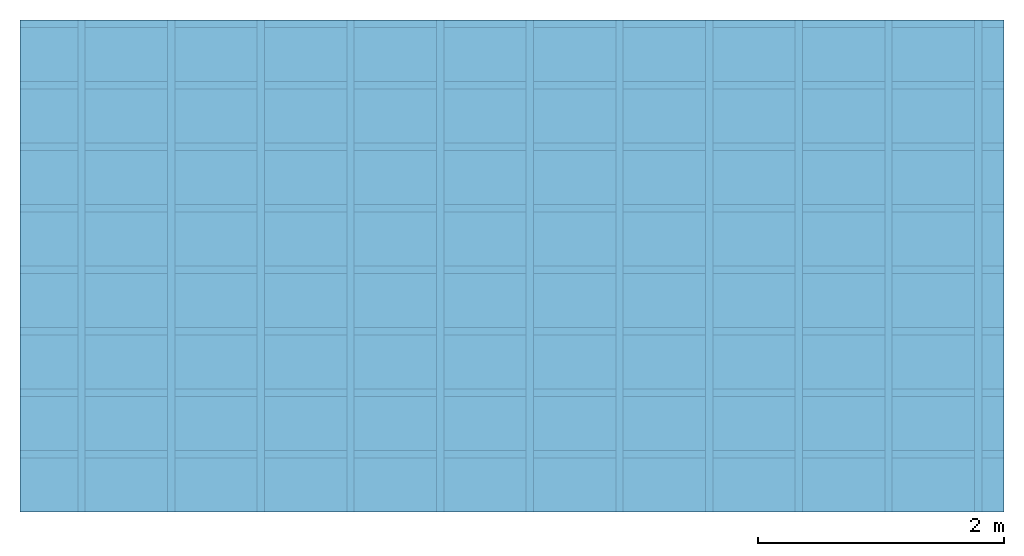
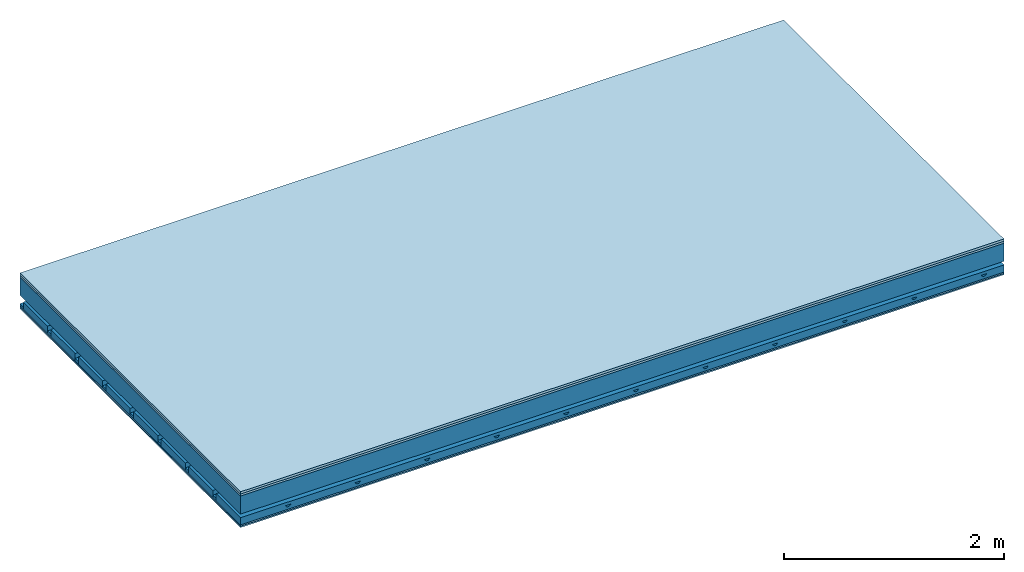
# One storey: 4 members, 4 plates, 1 element without a shape of its own.
"""IFC4 building model written with IfcOpenShell, lengths in metres."""

from ifc_helpers import new_model, si_unit, derived_unit, direction, frame, frame_2d, origin, origin_with_axes, place, context, project, spatial, polyline, rectangle, outline, extrude, material, layer, layer_set, type_object, element, aggregate, save


model = new_model("IFC4")

# Units and contexts
plan_context = context("Plan", 3, precision=1e-05, world=origin(), true_north=direction((0.0, 1.0)))
model_context = context("Model", 3, precision=1e-05, world=origin(), true_north=direction((0.0, 1.0)))
ifc_project = project(units=[si_unit("LENGTHUNIT", "METRE"), derived_unit("SOUNDPRESSUREUNIT", [(si_unit("PRESSUREUNIT", "PASCAL", prefix="MICRO"), 0)]), si_unit("ENERGYUNIT", "JOULE", prefix="MEGA"), si_unit("MASSUNIT", "GRAM", prefix="KILO"), derived_unit("THERMALTRANSMITTANCEUNIT", [(si_unit("POWERUNIT", "WATT"), 1), (si_unit("AREAUNIT", "SQUARE_METRE"), -1), (si_unit("THERMODYNAMICTEMPERATUREUNIT", "KELVIN"), -1)]), derived_unit("AREADENSITYUNIT", [(si_unit("MASSUNIT", "GRAM", prefix="KILO"), 1), (si_unit("AREAUNIT", "SQUARE_METRE"), -1)]), derived_unit("USERDEFINED", [(si_unit("ENERGYUNIT", "JOULE", prefix="MEGA"), 1), (si_unit("AREAUNIT", "SQUARE_METRE"), -1)])], contexts=[plan_context, model_context])

# Site, building, storey
site = spatial("IfcSite", under=ifc_project)
building_placement = place(None, origin())
building = spatial("IfcBuilding", under=site, at=building_placement)
storey_placement = place(building_placement, origin())
storey = spatial("IfcBuildingStorey", under=building, at=storey_placement)

# Slab, members, plates
ifc_material_1 = material(Name="Floor heating system Therm38 longitudinal", Category="03.007")
ifc_layer_1 = layer(ifc_material_1, 0.025, Name="On-material")
ifc_material_2 = material(Category="10.009")
ifc_layer_2 = layer(ifc_material_2, 0.022, Name="Impact sound insulation")
ifc_layer_3 = layer(None, 0.2, Name="Supporting structure")
ifc_material_3 = material(Name="no composite action")
ifc_layer_4 = layer(ifc_material_3, 0.0, Name="Bond")
ifc_layer_5 = layer(None, 0.093, Name="Coupling")
ifc_layer_6 = layer(None, 0.027, Name="Battens / profiles")
ifc_material_4 = material(Category="03.007")
ifc_layer_7 = layer(ifc_material_4, 0.015, Name="Ceiling covering 1st layer")
ifc_layer_8 = layer(ifc_material_4, 0.015, Name="Ceiling covering layer 2")
ifc_material_5 = material(Name="Glued joints")
ifc_layer_9 = layer(ifc_material_5, 0.0, Name="Surface / treatment")
ifc_layer_set = layer_set([ifc_layer_1, ifc_layer_2, ifc_layer_3, ifc_layer_4, ifc_layer_5, ifc_layer_6, ifc_layer_7, ifc_layer_8, ifc_layer_9])
slab_type = type_object("IfcSlabType", Name="A0901", PredefinedType="NOTDEFINED", material=ifc_layer_set)
slab_placement = place(None, frame((0.0, 0.0, 0.0), z_axis=(0.0, 0.0, -1.0), x_axis=(1.0, 0.0, 0.0)))
slab = element("IfcSlab", 1, at=slab_placement, inside=storey, type_object=slab_type, material=ifc_layer_set, Name="Slab #1")
ifc_material_6 = material()
member_1_placement = place(slab_placement, origin())
member_1 = element("IfcMember", 2, at=member_1_placement, material=ifc_material_6, Name="Supporting structure", context=plan_context, shape_type="SweptSolid", body=[
    extrude(rectangle(XDim=1.0, YDim=0.2, at=frame_2d((0.5, 0.1), x_axis=(1.0, 0.0))), frame((0.0, 4.0, 0.047), z_axis=(0.0, -1.0, 0.0), x_axis=(1.0, 0.0, 0.0)), (0.0, 0.0, 1.0), 4.0),
    extrude(rectangle(XDim=1.0, YDim=0.2, at=frame_2d((0.5, 0.1), x_axis=(1.0, 0.0))), frame((1.0, 4.0, 0.047), z_axis=(0.0, -1.0, 0.0), x_axis=(1.0, 0.0, 0.0)), (0.0, 0.0, 1.0), 4.0),
    extrude(rectangle(XDim=1.0, YDim=0.2, at=frame_2d((0.5, 0.1), x_axis=(1.0, 0.0))), frame((2.0, 4.0, 0.047), z_axis=(0.0, -1.0, 0.0), x_axis=(1.0, 0.0, 0.0)), (0.0, 0.0, 1.0), 4.0),
    extrude(rectangle(XDim=1.0, YDim=0.2, at=frame_2d((0.5, 0.1), x_axis=(1.0, 0.0))), frame((3.0, 4.0, 0.047), z_axis=(0.0, -1.0, 0.0), x_axis=(1.0, 0.0, 0.0)), (0.0, 0.0, 1.0), 4.0),
    extrude(rectangle(XDim=1.0, YDim=0.2, at=frame_2d((0.5, 0.1), x_axis=(1.0, 0.0))), frame((4.0, 4.0, 0.047), z_axis=(0.0, -1.0, 0.0), x_axis=(1.0, 0.0, 0.0)), (0.0, 0.0, 1.0), 4.0),
    extrude(rectangle(XDim=1.0, YDim=0.2, at=frame_2d((0.5, 0.1), x_axis=(1.0, 0.0))), frame((5.0, 4.0, 0.047), z_axis=(0.0, -1.0, 0.0), x_axis=(1.0, 0.0, 0.0)), (0.0, 0.0, 1.0), 4.0),
    extrude(rectangle(XDim=1.0, YDim=0.2, at=frame_2d((0.5, 0.1), x_axis=(1.0, 0.0))), frame((6.0, 4.0, 0.047), z_axis=(0.0, -1.0, 0.0), x_axis=(1.0, 0.0, 0.0)), (0.0, 0.0, 1.0), 4.0),
    extrude(rectangle(XDim=1.0, YDim=0.2, at=frame_2d((0.5, 0.1), x_axis=(1.0, 0.0))), frame((7.0, 4.0, 0.047), z_axis=(0.0, -1.0, 0.0), x_axis=(1.0, 0.0, 0.0)), (0.0, 0.0, 1.0), 4.0),
])
ifc_material_7 = material()
member_2_placement = place(slab_placement, origin())
member_2 = element("IfcMember", 3, at=member_2_placement, material=ifc_material_7, Name="Coupling", context=plan_context, shape_type="SweptSolid", body=[
    extrude(outline(polyline([(0.0, 0.0), (0.06, 0.0), (0.04, 0.02), (0.02, 0.02), (0.0, 0.0)])), frame((0.47, 4.0, 0.32), z_axis=(0.0, -1.0, 0.0), x_axis=(1.0, 0.0, 0.0)), (0.0, 0.0, 1.0), 4.0),
    extrude(outline(polyline([(0.0, 0.0), (0.06, 0.0), (0.04, 0.02), (0.02, 0.02), (0.0, 0.0)])), frame((1.199, 4.0, 0.32), z_axis=(0.0, -1.0, 0.0), x_axis=(1.0, 0.0, 0.0)), (0.0, 0.0, 1.0), 4.0),
    extrude(outline(polyline([(0.0, 0.0), (0.06, 0.0), (0.04, 0.02), (0.02, 0.02), (0.0, 0.0)])), frame((1.928, 4.0, 0.32), z_axis=(0.0, -1.0, 0.0), x_axis=(1.0, 0.0, 0.0)), (0.0, 0.0, 1.0), 4.0),
    extrude(outline(polyline([(0.0, 0.0), (0.06, 0.0), (0.04, 0.02), (0.02, 0.02), (0.0, 0.0)])), frame((2.657, 4.0, 0.32), z_axis=(0.0, -1.0, 0.0), x_axis=(1.0, 0.0, 0.0)), (0.0, 0.0, 1.0), 4.0),
    extrude(outline(polyline([(0.0, 0.0), (0.06, 0.0), (0.04, 0.02), (0.02, 0.02), (0.0, 0.0)])), frame((3.386, 4.0, 0.32), z_axis=(0.0, -1.0, 0.0), x_axis=(1.0, 0.0, 0.0)), (0.0, 0.0, 1.0), 4.0),
    extrude(outline(polyline([(0.0, 0.0), (0.06, 0.0), (0.04, 0.02), (0.02, 0.02), (0.0, 0.0)])), frame((4.115, 4.0, 0.32), z_axis=(0.0, -1.0, 0.0), x_axis=(1.0, 0.0, 0.0)), (0.0, 0.0, 1.0), 4.0),
    extrude(outline(polyline([(0.0, 0.0), (0.06, 0.0), (0.04, 0.02), (0.02, 0.02), (0.0, 0.0)])), frame((4.844, 4.0, 0.32), z_axis=(0.0, -1.0, 0.0), x_axis=(1.0, 0.0, 0.0)), (0.0, 0.0, 1.0), 4.0),
    extrude(outline(polyline([(0.0, 0.0), (0.06, 0.0), (0.04, 0.02), (0.02, 0.02), (0.0, 0.0)])), frame((5.573, 4.0, 0.32), z_axis=(0.0, -1.0, 0.0), x_axis=(1.0, 0.0, 0.0)), (0.0, 0.0, 1.0), 4.0),
    extrude(outline(polyline([(0.0, 0.0), (0.06, 0.0), (0.04, 0.02), (0.02, 0.02), (0.0, 0.0)])), frame((6.302, 4.0, 0.32), z_axis=(0.0, -1.0, 0.0), x_axis=(1.0, 0.0, 0.0)), (0.0, 0.0, 1.0), 4.0),
    extrude(outline(polyline([(0.0, 0.0), (0.06, 0.0), (0.04, 0.02), (0.02, 0.02), (0.0, 0.0)])), frame((7.031, 4.0, 0.32), z_axis=(0.0, -1.0, 0.0), x_axis=(1.0, 0.0, 0.0)), (0.0, 0.0, 1.0), 4.0),
    extrude(outline(polyline([(0.0, 0.0), (0.06, 0.0), (0.04, 0.02), (0.02, 0.02), (0.0, 0.0)])), frame((7.76, 4.0, 0.32), z_axis=(0.0, -1.0, 0.0), x_axis=(1.0, 0.0, 0.0)), (0.0, 0.0, 1.0), 4.0),
])
ifc_material_8 = material()
member_3_placement = place(slab_placement, origin())
member_3 = element("IfcMember", 4, at=member_3_placement, material=ifc_material_8, Name="Battens / profiles", context=plan_context, shape_type="SweptSolid", body=[
    extrude(rectangle(XDim=0.06, YDim=0.027, at=frame_2d((0.03, 0.0135), x_axis=(1.0, 0.0))), frame((0.0, 0.0, 0.34), z_axis=(1.0, 0.0, 0.0), x_axis=(0.0, 1.0, 0.0)), (0.0, 0.0, 1.0), 8.0),
    extrude(rectangle(XDim=0.06, YDim=0.027, at=frame_2d((0.03, 0.0135), x_axis=(1.0, 0.0))), frame((0.0, 0.5, 0.34), z_axis=(1.0, 0.0, 0.0), x_axis=(0.0, 1.0, 0.0)), (0.0, 0.0, 1.0), 8.0),
    extrude(rectangle(XDim=0.06, YDim=0.027, at=frame_2d((0.03, 0.0135), x_axis=(1.0, 0.0))), frame((0.0, 1.0, 0.34), z_axis=(1.0, 0.0, 0.0), x_axis=(0.0, 1.0, 0.0)), (0.0, 0.0, 1.0), 8.0),
    extrude(rectangle(XDim=0.06, YDim=0.027, at=frame_2d((0.03, 0.0135), x_axis=(1.0, 0.0))), frame((0.0, 1.5, 0.34), z_axis=(1.0, 0.0, 0.0), x_axis=(0.0, 1.0, 0.0)), (0.0, 0.0, 1.0), 8.0),
    extrude(rectangle(XDim=0.06, YDim=0.027, at=frame_2d((0.03, 0.0135), x_axis=(1.0, 0.0))), frame((0.0, 2.0, 0.34), z_axis=(1.0, 0.0, 0.0), x_axis=(0.0, 1.0, 0.0)), (0.0, 0.0, 1.0), 8.0),
    extrude(rectangle(XDim=0.06, YDim=0.027, at=frame_2d((0.03, 0.0135), x_axis=(1.0, 0.0))), frame((0.0, 2.5, 0.34), z_axis=(1.0, 0.0, 0.0), x_axis=(0.0, 1.0, 0.0)), (0.0, 0.0, 1.0), 8.0),
    extrude(rectangle(XDim=0.06, YDim=0.027, at=frame_2d((0.03, 0.0135), x_axis=(1.0, 0.0))), frame((0.0, 3.0, 0.34), z_axis=(1.0, 0.0, 0.0), x_axis=(0.0, 1.0, 0.0)), (0.0, 0.0, 1.0), 8.0),
    extrude(rectangle(XDim=0.06, YDim=0.027, at=frame_2d((0.03, 0.0135), x_axis=(1.0, 0.0))), frame((0.0, 3.5, 0.34), z_axis=(1.0, 0.0, 0.0), x_axis=(0.0, 1.0, 0.0)), (0.0, 0.0, 1.0), 8.0),
])
ifc_material_9 = material()
member_4_placement = place(slab_placement, origin())
member_4 = element("IfcMember", 5, at=member_4_placement, material=ifc_material_9, Name="Cavity", context=plan_context, shape_type="SweptSolid", body=[
    extrude(rectangle(XDim=0.44, YDim=0.08, at=frame_2d((0.22, 0.04), x_axis=(1.0, 0.0))), frame((0.0, 0.06, 0.287), z_axis=(1.0, 0.0, 0.0), x_axis=(0.0, 1.0, 0.0)), (0.0, 0.0, 1.0), 8.0),
    extrude(rectangle(XDim=0.44, YDim=0.08, at=frame_2d((0.22, 0.04), x_axis=(1.0, 0.0))), frame((0.0, 0.56, 0.287), z_axis=(1.0, 0.0, 0.0), x_axis=(0.0, 1.0, 0.0)), (0.0, 0.0, 1.0), 8.0),
    extrude(rectangle(XDim=0.44, YDim=0.08, at=frame_2d((0.22, 0.04), x_axis=(1.0, 0.0))), frame((0.0, 1.06, 0.287), z_axis=(1.0, 0.0, 0.0), x_axis=(0.0, 1.0, 0.0)), (0.0, 0.0, 1.0), 8.0),
    extrude(rectangle(XDim=0.44, YDim=0.08, at=frame_2d((0.22, 0.04), x_axis=(1.0, 0.0))), frame((0.0, 1.56, 0.287), z_axis=(1.0, 0.0, 0.0), x_axis=(0.0, 1.0, 0.0)), (0.0, 0.0, 1.0), 8.0),
    extrude(rectangle(XDim=0.44, YDim=0.08, at=frame_2d((0.22, 0.04), x_axis=(1.0, 0.0))), frame((0.0, 2.06, 0.287), z_axis=(1.0, 0.0, 0.0), x_axis=(0.0, 1.0, 0.0)), (0.0, 0.0, 1.0), 8.0),
    extrude(rectangle(XDim=0.44, YDim=0.08, at=frame_2d((0.22, 0.04), x_axis=(1.0, 0.0))), frame((0.0, 2.56, 0.287), z_axis=(1.0, 0.0, 0.0), x_axis=(0.0, 1.0, 0.0)), (0.0, 0.0, 1.0), 8.0),
    extrude(rectangle(XDim=0.44, YDim=0.08, at=frame_2d((0.22, 0.04), x_axis=(1.0, 0.0))), frame((0.0, 3.06, 0.287), z_axis=(1.0, 0.0, 0.0), x_axis=(0.0, 1.0, 0.0)), (0.0, 0.0, 1.0), 8.0),
    extrude(rectangle(XDim=0.44, YDim=0.08, at=frame_2d((0.22, 0.04), x_axis=(1.0, 0.0))), frame((0.0, 3.56, 0.287), z_axis=(1.0, 0.0, 0.0), x_axis=(0.0, 1.0, 0.0)), (0.0, 0.0, 1.0), 8.0),
])
plate_1_placement = place(slab_placement, origin())
plate_1 = element("IfcPlate", 6, at=plate_1_placement, material=ifc_material_1, Name="On-material", context=plan_context, shape_type="SweptSolid", body=[
    extrude(rectangle(XDim=8.0, YDim=4.0, at=frame_2d((4.0, 2.0), x_axis=(1.0, 0.0))), origin_with_axes(), (0.0, 0.0, 1.0), 0.025),
])
plate_2_placement = place(slab_placement, origin())
plate_2 = element("IfcPlate", 7, at=plate_2_placement, material=ifc_material_2, Name="Impact sound insulation", context=plan_context, shape_type="SweptSolid", body=[
    extrude(rectangle(XDim=8.0, YDim=4.0, at=frame_2d((4.0, 2.0), x_axis=(1.0, 0.0))), frame((0.0, 0.0, 0.025), z_axis=(0.0, 0.0, 1.0), x_axis=(1.0, 0.0, 0.0)), (0.0, 0.0, 1.0), 0.022),
])
plate_3_placement = place(slab_placement, origin())
plate_3 = element("IfcPlate", 8, at=plate_3_placement, material=ifc_material_4, Name="Ceiling covering 1st layer", context=plan_context, shape_type="SweptSolid", body=[
    extrude(rectangle(XDim=8.0, YDim=4.0, at=frame_2d((4.0, 2.0), x_axis=(1.0, 0.0))), frame((0.0, 0.0, 0.367), z_axis=(0.0, 0.0, 1.0), x_axis=(1.0, 0.0, 0.0)), (0.0, 0.0, 1.0), 0.015),
])
plate_4_placement = place(slab_placement, origin())
plate_4 = element("IfcPlate", 9, at=plate_4_placement, material=ifc_material_4, Name="Ceiling covering layer 2", context=plan_context, shape_type="SweptSolid", body=[
    extrude(rectangle(XDim=8.0, YDim=4.0, at=frame_2d((4.0, 2.0), x_axis=(1.0, 0.0))), frame((0.0, 0.0, 0.382), z_axis=(0.0, 0.0, 1.0), x_axis=(1.0, 0.0, 0.0)), (0.0, 0.0, 1.0), 0.015),
])
aggregate(slab, [plate_1, plate_2, member_1, member_2, member_3, member_4, plate_3, plate_4])

save(model, "model.ifc")
